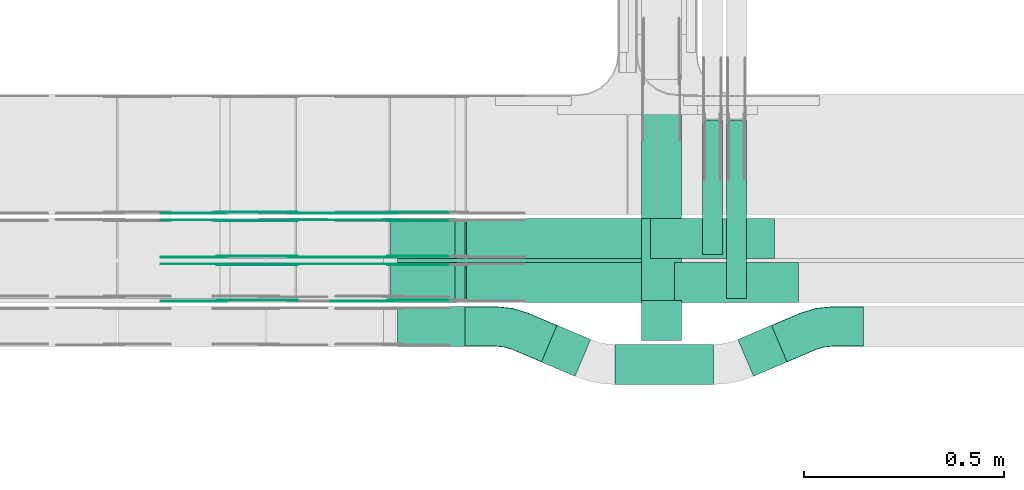
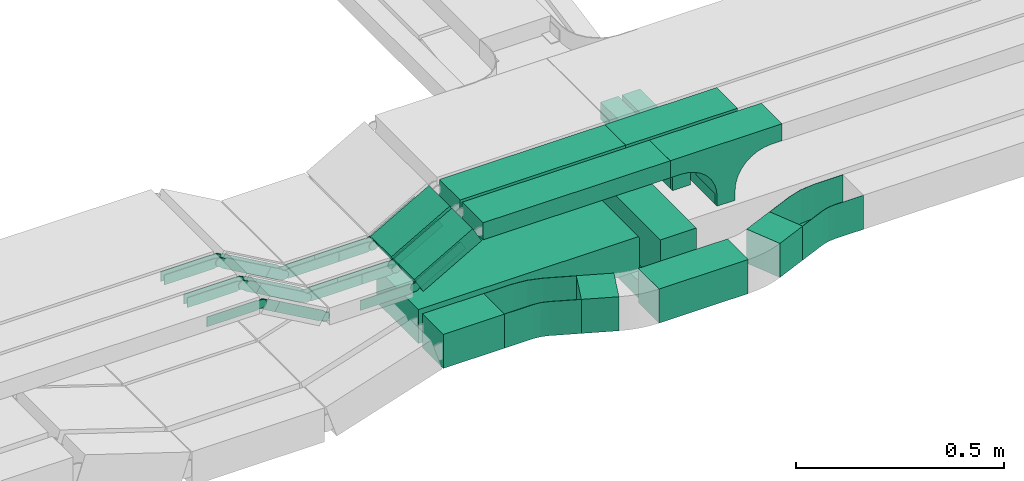
# One storey, part 11 of 27: 34 flow fittings, 13 flow segments.
"""IFC2X3 building model written with IfcOpenShell, lengths in millimetres."""

from ifc_helpers import new_model, entity, si_unit, converted_unit, derived_unit, direction, frame, frame_2d, origin, origin_2d_with_axis, place, context, subcontext, project, spatial, polyline, circle_curve, parameter, trimmed, segment, composite_curve, rectangle, outline, extrude, faceted_brep, source, transform, mapped, material, material_list, type_object, type_shapes, element, save


model = new_model("IFC2X3")

# Units and contexts
model_context = context("Model", 3, precision=0.01, world=origin(), true_north=direction((6.12303176911189e-17, 1.0)))
body_context = subcontext(model_context, "Body", "Model", "MODEL_VIEW")
ifc_project = project(units=[si_unit("LENGTHUNIT", "METRE", prefix="MILLI"), si_unit("AREAUNIT", "SQUARE_METRE"), si_unit("VOLUMEUNIT", "CUBIC_METRE"), converted_unit("PLANEANGLEUNIT", "DEGREE", entity("IfcRatioMeasure", 0.0174532925199433), si_unit("PLANEANGLEUNIT", "RADIAN"), dimensions=[0, 0, 0, 0, 0, 0, 0]), si_unit("MASSUNIT", "GRAM", prefix="KILO"), derived_unit("MASSDENSITYUNIT", [(si_unit("MASSUNIT", "GRAM", prefix="KILO"), 1), (si_unit("LENGTHUNIT", "METRE"), -3)]), derived_unit("MOMENTOFINERTIAUNIT", [(si_unit("LENGTHUNIT", "METRE"), 4)]), si_unit("TIMEUNIT", "SECOND"), si_unit("FREQUENCYUNIT", "HERTZ"), si_unit("THERMODYNAMICTEMPERATUREUNIT", "DEGREE_CELSIUS"), derived_unit("THERMALTRANSMITTANCEUNIT", [(si_unit("MASSUNIT", "GRAM", prefix="KILO"), 1), (si_unit("THERMODYNAMICTEMPERATUREUNIT", "KELVIN"), -1), (si_unit("TIMEUNIT", "SECOND"), -3)]), derived_unit("VOLUMETRICFLOWRATEUNIT", [(si_unit("LENGTHUNIT", "METRE"), 3), (si_unit("TIMEUNIT", "SECOND"), -1)]), derived_unit("MASSFLOWRATEUNIT", [(si_unit("MASSUNIT", "GRAM", prefix="KILO"), 1), (si_unit("TIMEUNIT", "SECOND"), -1)]), derived_unit("ROTATIONALFREQUENCYUNIT", [(si_unit("TIMEUNIT", "SECOND"), -1)]), si_unit("ELECTRICCURRENTUNIT", "AMPERE"), si_unit("ELECTRICVOLTAGEUNIT", "VOLT"), si_unit("POWERUNIT", "WATT"), si_unit("FORCEUNIT", "NEWTON", prefix="KILO"), si_unit("ILLUMINANCEUNIT", "LUX"), si_unit("LUMINOUSFLUXUNIT", "LUMEN"), si_unit("LUMINOUSINTENSITYUNIT", "CANDELA"), derived_unit("USERDEFINED", [(si_unit("MASSUNIT", "GRAM", prefix="KILO"), -1), (si_unit("LENGTHUNIT", "METRE"), -2), (si_unit("TIMEUNIT", "SECOND"), 3), (si_unit("LUMINOUSFLUXUNIT", "LUMEN"), 1)]), derived_unit("LINEARVELOCITYUNIT", [(si_unit("LENGTHUNIT", "METRE"), 1), (si_unit("TIMEUNIT", "SECOND"), -1)]), si_unit("PRESSUREUNIT", "PASCAL"), derived_unit("USERDEFINED", [(si_unit("LENGTHUNIT", "METRE"), -2), (si_unit("MASSUNIT", "GRAM", prefix="KILO"), 1), (si_unit("TIMEUNIT", "SECOND"), -2)]), derived_unit("LINEARFORCEUNIT", [(si_unit("MASSUNIT", "GRAM", prefix="KILO"), 1), (si_unit("LENGTHUNIT", "METRE"), 1), (si_unit("TIMEUNIT", "SECOND"), -2), (si_unit("LENGTHUNIT", "METRE"), -1)]), derived_unit("PLANARFORCEUNIT", [(si_unit("MASSUNIT", "GRAM", prefix="KILO"), 1), (si_unit("LENGTHUNIT", "METRE"), 1), (si_unit("TIMEUNIT", "SECOND"), -2), (si_unit("LENGTHUNIT", "METRE"), -2)])], contexts=[model_context])

# Site, building, storey
site_placement = place(None, origin())
site = spatial("IfcSite", under=ifc_project, at=site_placement, CompositionType="ELEMENT")
building_placement = place(site_placement, origin())
building = spatial("IfcBuilding", under=site, at=building_placement, CompositionType="ELEMENT")
storey_placement = place(building_placement, origin())
storey = spatial("IfcBuildingStorey", under=building, at=storey_placement, CompositionType="ELEMENT", Elevation=0.0)

# Flow segments
cable_carrier_segment_type = type_object("IfcCableCarrierSegmentType", PredefinedType="CABLETRAYSEGMENT")
flow_segment_1_placement = place(storey_placement, frame((35767.46, 8409.92, 2721.0)))
element("IfcFlowSegment", 1, at=flow_segment_1_placement, inside=storey, type_object=cable_carrier_segment_type, context=body_context, shape_type="SweptSolid", body=[
    extrude(rectangle(XDim=446.583630582365, YDim=49.9999999999973, at=origin_2d_with_axis()), frame((25.0, 223.29, 0.0), z_axis=(0.0, 0.0, 1.0), x_axis=(0.0, -1.0, 0.0)), (0.0, 0.0, 1.0), 50.0000000000005),
])
flow_segment_2_placement = place(storey_placement, frame((35488.35, 8195.26, 2600.0)))
element("IfcFlowSegment", 2, at=flow_segment_2_placement, inside=storey, type_object=cable_carrier_segment_type, context=body_context, shape_type="SweptSolid", body=[
    extrude(rectangle(XDim=247.288948924523, YDim=99.9999999999989, at=origin_2d_with_axis()), frame((123.64, 50.0, 0.0)), (0.0, 0.0, 1.0), 100.0),
])
flow_segment_3_placement = place(storey_placement, frame((35304.82, 8215.53, 2600.0)))
element("IfcFlowSegment", 3, at=flow_segment_3_placement, inside=storey, type_object=cable_carrier_segment_type, context=body_context, shape_type="SweptSolid", body=[
    extrude(rectangle(XDim=91.1810821540981, YDim=100.000000000001, at=origin_2d_with_axis()), frame((61.5, 63.84, 0.0), z_axis=(0.0, 0.0, 1.0), x_axis=(0.920504853452403, -0.390731128489362, 0.0)), (0.0, 0.0, 1.0), 100.0),
])
flow_segment_4_placement = place(storey_placement, frame((34944.23, 8290.0, 2600.0)))
element("IfcFlowSegment", 4, at=flow_segment_4_placement, inside=storey, type_object=cable_carrier_segment_type, context=body_context, shape_type="SweptSolid", body=[
    extrude(rectangle(XDim=169.658005217947, YDim=99.9999999999989, at=origin_2d_with_axis()), frame((84.83, 50.0, 0.0), z_axis=(0.0, 0.0, 1.0), x_axis=(-1.0, 0.0, 0.0)), (0.0, 0.0, 1.0), 100.000000000001),
])
flow_segment_5_placement = place(storey_placement, frame((35555.11, 8327.89, 2520.12)))
element("IfcFlowSegment", 5, at=flow_segment_5_placement, inside=storey, type_object=cable_carrier_segment_type, context=body_context, shape_type="SweptSolid", body=[
    extrude(rectangle(XDim=626.717650502026, YDim=100.000000000003, at=origin_2d_with_axis()), frame((50.0, 313.36, 0.0), z_axis=(0.0, 0.0, 1.0), x_axis=(0.0, -1.0, 0.0)), (0.0, 0.0, 1.0), 50.0000000000005),
])
flow_segment_6_placement = place(storey_placement, frame((34944.23, 8410.17, 2600.0)))
element("IfcFlowSegment", 6, at=flow_segment_6_placement, inside=storey, type_object=cable_carrier_segment_type, context=body_context, shape_type="SweptSolid", body=[
    extrude(rectangle(XDim=660.477953416512, YDim=200.0, at=origin_2d_with_axis()), frame((330.24, 100.0, 0.0), z_axis=(0.0, 0.0, 1.0), x_axis=(-1.0, 0.0, 0.0)), (0.0, 0.0, 1.0), 100.0),
])
flow_segment_7_placement = place(storey_placement, frame((35555.11, 8305.17, 2570.12)))
element("IfcFlowSegment", 7, at=flow_segment_7_placement, inside=storey, type_object=cable_carrier_segment_type, context=body_context, shape_type="SweptSolid", body=[
    extrude(rectangle(XDim=100.000000000003, YDim=100.000000000001, at=origin_2d_with_axis()), frame((50.0, 50.0, 0.0), z_axis=(0.0, 0.0, 1.0), x_axis=(-1.0, 0.0, 0.0)), (0.0, 0.0, 1.0), 50.8822343726412),
])
flow_segment_8_placement = place(storey_placement, frame((35796.17, 8215.53, 2600.0)))
element("IfcFlowSegment", 8, at=flow_segment_8_placement, inside=storey, type_object=cable_carrier_segment_type, context=body_context, shape_type="SweptSolid", body=[
    extrude(rectangle(XDim=91.1810821540889, YDim=100.000000000001, at=origin_2d_with_axis()), frame((61.5, 63.84, 0.0), z_axis=(0.0, 0.0, 1.0), x_axis=(-0.920504853452401, -0.390731128489366, 0.0)), (0.0, 0.0, 1.0), 99.9999999999999),
])
flow_segment_9_placement = place(storey_placement, frame((35117.82, 8510.0, 2850.0)))
element("IfcFlowSegment", 9, at=flow_segment_9_placement, inside=storey, type_object=cable_carrier_segment_type, context=body_context, shape_type="SweptSolid", body=[
    extrude(rectangle(XDim=459.62214617131, YDim=100.000000000001, at=origin_2d_with_axis()), frame((229.81, 50.0, 0.0), z_axis=(0.0, 0.0, 1.0), x_axis=(-1.0, 0.0, 0.0)), (0.0, 0.0, 1.0), 50.0000000000011),
])
flow_segment_10_placement = place(storey_placement, frame((35117.82, 8400.0, 2850.0)))
element("IfcFlowSegment", 10, at=flow_segment_10_placement, inside=storey, type_object=cable_carrier_segment_type, context=body_context, shape_type="SweptSolid", body=[
    extrude(rectangle(XDim=519.774157422868, YDim=100.000000000001, at=origin_2d_with_axis()), frame((259.89, 50.0, 0.0), z_axis=(0.0, 0.0, 1.0), x_axis=(-1.0, 0.0, 0.0)), (0.0, 0.0, 1.0), 50.0000000000005),
])
flow_segment_11_placement = place(storey_placement, frame((34927.11, 8400.0, 2756.67)))
element("IfcFlowSegment", 11, at=flow_segment_11_placement, inside=storey, type_object=cable_carrier_segment_type, context=body_context, shape_type="SweptSolid", body=[
    extrude(rectangle(XDim=49.999999999999, YDim=100.000000000001, at=origin_2d_with_axis()), frame((12.37, 50.0, 21.73), z_axis=(0.869016356406197, 0.0, 0.494783358954703), x_axis=(-0.494783358954703, 0.0, 0.869016356406197)), (0.0, 0.0, 1.0), 186.565135152812),
])
flow_segment_12_placement = place(storey_placement, frame((34927.11, 8510.0, 2756.67)))
element("IfcFlowSegment", 12, at=flow_segment_12_placement, inside=storey, type_object=cable_carrier_segment_type, context=body_context, shape_type="SweptSolid", body=[
    extrude(rectangle(XDim=49.9999999999996, YDim=100.000000000001, at=origin_2d_with_axis()), frame((12.37, 50.0, 21.73), z_axis=(0.869016356406348, 0.0, 0.494783358954437), x_axis=(-0.494783358954437, 0.0, 0.869016356406348)), (0.0, 0.0, 1.0), 186.565135152931),
])
flow_segment_13_placement = place(storey_placement, frame((35707.46, 8520.26, 2721.0)))
element("IfcFlowSegment", 13, at=flow_segment_13_placement, inside=storey, type_object=cable_carrier_segment_type, context=body_context, shape_type="SweptSolid", body=[
    extrude(rectangle(XDim=336.244538193396, YDim=49.9999999999973, at=origin_2d_with_axis()), frame((25.0, 168.12, 0.0), z_axis=(0.0, 0.0, 1.0), x_axis=(0.0, -1.0, 0.0)), (0.0, 0.0, 1.0), 50.0000000000005),
])

# Flow fittings
ifc_material_1 = material()
cable_carrier_fitting_type_1 = type_object("IfcCableCarrierFittingType", Name="470_DKC_S5_CPO 45 horizontal angle:-", PredefinedType="NOTDEFINED", material=ifc_material_1)
shared_shape_1 = source(origin(), body_context, "Body", "Brep", [
    faceted_brep([(-109.59, -49.2, -49.2), (-109.59, 49.2, -49.2), (-109.59, 49.2, 50.0), (-109.59, 50.0, 50.0), (-109.59, 50.0, -50.0), (-109.59, -50.0, -50.0), (-109.59, -50.0, 50.0), (-109.59, -49.2, 50.0), (-30.52, -50.0, -50.0), (-30.52, -50.0, 50.0), (9.36, -45.98, 50.0), (47.63, -34.1, 50.0), (120.41, -3.21, 50.0), (120.1, -2.47, 50.0), (47.32, -33.36, 50.0), (9.2, -45.2, 50.0), (-30.52, -49.2, 50.0), (-30.52, 49.2, 50.0), (-10.42, 51.22, 50.0), (8.87, 57.21, 50.0), (81.65, 88.11, 50.0), (81.34, 88.84, 50.0), (8.56, 57.95, 50.0), (-10.58, 52.01, 50.0), (-30.52, 50.0, 50.0), (-30.52, -49.2, -49.2), (9.2, -45.2, -49.2), (47.32, -33.36, -49.2), (120.1, -2.47, -49.2), (81.65, 88.11, -49.2), (8.87, 57.21, -49.2), (-10.42, 51.22, -49.2), (-30.52, 49.2, -49.2), (-30.52, 50.0, -50.0), (-10.58, 52.01, -50.0), (8.56, 57.95, -50.0), (81.34, 88.84, -50.0), (120.41, -3.21, -50.0), (47.63, -34.1, -50.0), (9.36, -45.98, -50.0)], [[[0, 1, 2, 3, 4, 5, 6, 7]], [[6, 5, 8, 9]], [[6, 9, 10, 11, 12, 13, 14, 15, 16, 7]], [[2, 17, 18, 19, 20, 21, 22, 23, 24, 3]], [[0, 7, 16, 25]], [[0, 25, 26, 27, 28, 29, 30, 31, 32, 1]], [[2, 1, 32, 17]], [[4, 3, 24, 33]], [[4, 33, 34, 35, 36, 37, 38, 39, 8, 5]], [[9, 8, 39, 10]], [[39, 38, 11, 10]], [[26, 25, 16, 15]], [[15, 14, 27, 26]], [[17, 32, 31, 18]], [[18, 31, 30, 19]], [[34, 33, 24, 23]], [[22, 35, 34, 23]], [[36, 21, 20, 29, 28, 13, 12, 37]], [[11, 38, 37, 12]], [[27, 14, 13, 28]], [[19, 30, 29, 20]], [[35, 22, 21, 36]]]),
])
type_shapes(cable_carrier_fitting_type_1, [shared_shape_1])
for number, where, z_axis, x_axis, name in (
    (14, (36000.52, 8340.0, 2650.0), (0.0, 0.0, 1.0), (-1.0, 0.0, 0.0), "470_DKC_S5_45 horizontal angle"),
    (15, (35223.48, 8340.0, 2650.0), (0.0, 0.0, 1.0), (-0.920504853452403, 0.390731128489362, 0.0), "470_DKC_S5_45 horizontal angle"),
):
    element("IfcFlowFitting", number, at=place(storey_placement, frame(where, z_axis=z_axis, x_axis=x_axis)), inside=storey, type_object=cable_carrier_fitting_type_1, material=ifc_material_1, Name=name, ObjectType="470_DKC_S5_CPO 45 horizontal angle:-", context=body_context, shape_type="MappedRepresentation", body=[
        mapped(shared_shape_1, transform((0.0, 0.0, 0.0), scale=1.0)),
    ])
ifc_material_2 = material(Name="G")
cable_carrier_fitting_type_2 = type_object("IfcCableCarrierFittingType", PredefinedType="NOTDEFINED", material=ifc_material_2)
shared_shape_2 = source(origin(), body_context, "Body", "SweptSolid", [
    extrude(outline(composite_curve([segment(trimmed(circle_curve(frame_2d((-44.59, 0.0), x_axis=(1.0, 0.0)), 12.5), [parameter(90.0000000000007)], [parameter(270.0)], True, "PARAMETER"), True, "CONTINUOUS"), segment(polyline([(-44.59, -12.5), (-33.09, -12.5)]), True, "CONTINUOUS"), segment(polyline([(-33.09, -12.5), (-31.23, -14.5)]), True, "CONTINUOUS"), segment(polyline([(-31.23, -14.5), (108.91, -14.5)]), True, "CONTINUOUS"), segment(polyline([(108.91, -14.5), (108.91, 14.5)]), True, "CONTINUOUS"), segment(polyline([(108.91, 14.5), (-31.23, 14.5)]), True, "CONTINUOUS"), segment(polyline([(-31.23, 14.5), (-33.09, 12.5)]), True, "CONTINUOUS"), segment(polyline([(-33.09, 12.5), (-44.59, 12.5)]), True, "CONTINUOUS")], self_intersect=False)), frame((44.59, 0.0, 0.0), z_axis=(0.0, 0.0, -1.0), x_axis=(1.0, 0.0, 0.0)), (0.0, 0.0, -1.0), 2.0),
])
type_shapes(cable_carrier_fitting_type_2, [shared_shape_2])
flow_fitting_1_placement = place(storey_placement, frame((34683.26, 8493.46, 2774.1), z_axis=(0.0, 1.0, 0.0), x_axis=(-0.869016356406185, 0.0, 0.494783358954723)))
element("IfcFlowFitting", 16, at=flow_fitting_1_placement, inside=storey, type_object=cable_carrier_fitting_type_2, material=ifc_material_2, context=body_context, shape_type="MappedRepresentation", body=[
    mapped(shared_shape_2, transform((0.0, 0.0, 0.0), scale=1.0)),
])
cable_carrier_fitting_type_3 = type_object("IfcCableCarrierFittingType", PredefinedType="NOTDEFINED", material=ifc_material_2)
type_shapes(cable_carrier_fitting_type_3, [shared_shape_2])
flow_fitting_2_placement = place(storey_placement, frame((34931.93, 8495.46, 2774.1), z_axis=(0.0, 1.0, 0.0), x_axis=(-1.0, 0.0, 0.0)))
element("IfcFlowFitting", 17, at=flow_fitting_2_placement, inside=storey, type_object=cable_carrier_fitting_type_3, material=ifc_material_2, context=body_context, shape_type="MappedRepresentation", body=[
    mapped(shared_shape_2, transform((0.0, 0.0, 0.0), scale=1.0)),
])
flow_fitting_3_placement = place(storey_placement, frame((34931.93, 8406.54, 2774.1), z_axis=(0.0, -1.0, 0.0), x_axis=(0.869016356406185, 0.0, 0.494783358954723)))
element("IfcFlowFitting", 18, at=flow_fitting_3_placement, inside=storey, type_object=cable_carrier_fitting_type_2, material=ifc_material_2, context=body_context, shape_type="MappedRepresentation", body=[
    mapped(shared_shape_2, transform((0.0, 0.0, 0.0), scale=1.0)),
])
flow_fitting_4_placement = place(storey_placement, frame((34683.26, 8514.54, 2774.1), z_axis=(0.0, -1.0, 0.0), x_axis=(1.0, 0.0, 0.0)))
element("IfcFlowFitting", 19, at=flow_fitting_4_placement, inside=storey, type_object=cable_carrier_fitting_type_3, material=ifc_material_2, context=body_context, shape_type="MappedRepresentation", body=[
    mapped(shared_shape_2, transform((0.0, 0.0, 0.0), scale=1.0)),
])
flow_fitting_5_placement = place(storey_placement, frame((34683.26, 8603.46, 2774.1), z_axis=(0.0, 1.0, 0.0), x_axis=(-0.869016356406185, 0.0, 0.494783358954723)))
element("IfcFlowFitting", 20, at=flow_fitting_5_placement, inside=storey, type_object=cable_carrier_fitting_type_2, material=ifc_material_2, context=body_context, shape_type="MappedRepresentation", body=[
    mapped(shared_shape_2, transform((0.0, 0.0, 0.0), scale=1.0)),
])
flow_fitting_6_placement = place(storey_placement, frame((34931.93, 8605.46, 2774.1), z_axis=(0.0, 1.0, 0.0), x_axis=(-1.0, 0.0, 0.0)))
element("IfcFlowFitting", 21, at=flow_fitting_6_placement, inside=storey, type_object=cable_carrier_fitting_type_3, material=ifc_material_2, context=body_context, shape_type="MappedRepresentation", body=[
    mapped(shared_shape_2, transform((0.0, 0.0, 0.0), scale=1.0)),
])
flow_fitting_7_placement = place(storey_placement, frame((34931.93, 8516.54, 2774.1), z_axis=(0.0, -1.0, 0.0), x_axis=(0.869016356406185, 0.0, 0.494783358954723)))
element("IfcFlowFitting", 22, at=flow_fitting_7_placement, inside=storey, type_object=cable_carrier_fitting_type_2, material=ifc_material_2, context=body_context, shape_type="MappedRepresentation", body=[
    mapped(shared_shape_2, transform((0.0, 0.0, 0.0), scale=1.0)),
])
flow_fitting_8_placement = place(storey_placement, frame((34683.26, 8624.54, 2774.1), z_axis=(0.0, -1.0, 0.0), x_axis=(1.0, 0.0, 0.0)))
element("IfcFlowFitting", 23, at=flow_fitting_8_placement, inside=storey, type_object=cable_carrier_fitting_type_3, material=ifc_material_2, context=body_context, shape_type="MappedRepresentation", body=[
    mapped(shared_shape_2, transform((0.0, 0.0, 0.0), scale=1.0)),
])
flow_fitting_9_placement = place(storey_placement, frame((34931.93, 8626.54, 2774.1), z_axis=(0.0, -1.0, 0.0), x_axis=(0.869016356406185, 0.0, 0.494783358954723)))
element("IfcFlowFitting", 24, at=flow_fitting_9_placement, inside=storey, type_object=cable_carrier_fitting_type_2, material=ifc_material_2, context=body_context, shape_type="MappedRepresentation", body=[
    mapped(shared_shape_2, transform((0.0, 0.0, 0.0), scale=1.0)),
])
for number, where, z_axis, x_axis in (
    (25, (34506.05, 8624.54, 2875.0), (0.0, -1.0, 0.0), (-1.0, 0.0, 0.0)),
    (26, (34506.05, 8514.54, 2875.0), (0.0, -1.0, 0.0), (-1.0, 0.0, 0.0)),
):
    element("IfcFlowFitting", number, at=place(storey_placement, frame(where, z_axis=z_axis, x_axis=x_axis)), inside=storey, type_object=cable_carrier_fitting_type_3, material=ifc_material_2, context=body_context, shape_type="MappedRepresentation", body=[
        mapped(shared_shape_2, transform((0.0, 0.0, 0.0), scale=1.0)),
    ])
flow_fitting_10_placement = place(storey_placement, frame((34506.05, 8603.46, 2875.0), z_axis=(0.0, 1.0, 0.0), x_axis=(0.869016356406338, 0.0, -0.494783358954455)))
element("IfcFlowFitting", 27, at=flow_fitting_10_placement, inside=storey, type_object=cable_carrier_fitting_type_2, material=ifc_material_2, context=body_context, shape_type="MappedRepresentation", body=[
    mapped(shared_shape_2, transform((0.0, 0.0, 0.0), scale=1.0)),
])
flow_fitting_11_placement = place(storey_placement, frame((34506.05, 8404.54, 2875.0), z_axis=(0.0, -1.0, 0.0), x_axis=(-1.0, 0.0, 0.0)))
element("IfcFlowFitting", 28, at=flow_fitting_11_placement, inside=storey, type_object=cable_carrier_fitting_type_3, material=ifc_material_2, context=body_context, shape_type="MappedRepresentation", body=[
    mapped(shared_shape_2, transform((0.0, 0.0, 0.0), scale=1.0)),
])
flow_fitting_12_placement = place(storey_placement, frame((34506.05, 8493.46, 2875.0), z_axis=(0.0, 1.0, 0.0), x_axis=(0.869016356406185, 0.0, -0.494783358954723)))
element("IfcFlowFitting", 29, at=flow_fitting_12_placement, inside=storey, type_object=cable_carrier_fitting_type_2, material=ifc_material_2, context=body_context, shape_type="MappedRepresentation", body=[
    mapped(shared_shape_2, transform((0.0, 0.0, 0.0), scale=1.0)),
])
cable_carrier_fitting_type_4 = type_object("IfcCableCarrierFittingType", PredefinedType="NOTDEFINED", material=ifc_material_2)
shared_shape_3 = source(origin(), body_context, "Body", "SweptSolid", [
    extrude(outline(composite_curve([segment(trimmed(circle_curve(frame_2d((-44.59, 0.0), x_axis=(1.0, 0.0)), 12.5), [parameter(90.0000000000007)], [parameter(270.0)], True, "PARAMETER"), True, "CONTINUOUS"), segment(polyline([(-44.59, -12.5), (-33.09, -12.5)]), True, "CONTINUOUS"), segment(polyline([(-33.09, -12.5), (-31.23, -14.5)]), True, "CONTINUOUS"), segment(polyline([(-31.23, -14.5), (108.91, -14.5)]), True, "CONTINUOUS"), segment(polyline([(108.91, -14.5), (108.91, 14.5)]), True, "CONTINUOUS"), segment(polyline([(108.91, 14.5), (-31.23, 14.5)]), True, "CONTINUOUS"), segment(polyline([(-31.23, 14.5), (-33.09, 12.5)]), True, "CONTINUOUS"), segment(polyline([(-33.09, 12.5), (-44.59, 12.5)]), True, "CONTINUOUS")], self_intersect=False)), frame((44.59, 0.0, 0.0)), (0.0, 0.0, 1.0), 2.0),
])
type_shapes(cable_carrier_fitting_type_4, [shared_shape_3])
flow_fitting_13_placement = place(storey_placement, frame((34683.26, 8495.46, 2774.1), z_axis=(0.0, 1.0, 0.0), x_axis=(1.0, 0.0, 0.0)))
element("IfcFlowFitting", 30, at=flow_fitting_13_placement, inside=storey, type_object=cable_carrier_fitting_type_4, material=ifc_material_2, context=body_context, shape_type="MappedRepresentation", body=[
    mapped(shared_shape_3, transform((0.0, 0.0, 0.0), scale=1.0)),
])
cable_carrier_fitting_type_5 = type_object("IfcCableCarrierFittingType", PredefinedType="NOTDEFINED", material=ifc_material_2)
type_shapes(cable_carrier_fitting_type_5, [shared_shape_3])
flow_fitting_14_placement = place(storey_placement, frame((34683.26, 8406.54, 2774.1), z_axis=(0.0, -1.0, 0.0), x_axis=(-0.869016356406185, 0.0, 0.494783358954723)))
element("IfcFlowFitting", 31, at=flow_fitting_14_placement, inside=storey, type_object=cable_carrier_fitting_type_5, material=ifc_material_2, context=body_context, shape_type="MappedRepresentation", body=[
    mapped(shared_shape_3, transform((0.0, 0.0, 0.0), scale=1.0)),
])
flow_fitting_15_placement = place(storey_placement, frame((34931.93, 8404.54, 2774.1), z_axis=(0.0, -1.0, 0.0), x_axis=(-1.0, 0.0, 0.0)))
element("IfcFlowFitting", 32, at=flow_fitting_15_placement, inside=storey, type_object=cable_carrier_fitting_type_4, material=ifc_material_2, context=body_context, shape_type="MappedRepresentation", body=[
    mapped(shared_shape_3, transform((0.0, 0.0, 0.0), scale=1.0)),
])
flow_fitting_16_placement = place(storey_placement, frame((34931.93, 8493.46, 2774.1), z_axis=(0.0, 1.0, 0.0), x_axis=(0.869016356406185, 0.0, 0.494783358954723)))
element("IfcFlowFitting", 33, at=flow_fitting_16_placement, inside=storey, type_object=cable_carrier_fitting_type_5, material=ifc_material_2, context=body_context, shape_type="MappedRepresentation", body=[
    mapped(shared_shape_3, transform((0.0, 0.0, 0.0), scale=1.0)),
])
flow_fitting_17_placement = place(storey_placement, frame((34683.26, 8605.46, 2774.1), z_axis=(0.0, 1.0, 0.0), x_axis=(1.0, 0.0, 0.0)))
element("IfcFlowFitting", 34, at=flow_fitting_17_placement, inside=storey, type_object=cable_carrier_fitting_type_4, material=ifc_material_2, context=body_context, shape_type="MappedRepresentation", body=[
    mapped(shared_shape_3, transform((0.0, 0.0, 0.0), scale=1.0)),
])
flow_fitting_18_placement = place(storey_placement, frame((34683.26, 8516.54, 2774.1), z_axis=(0.0, -1.0, 0.0), x_axis=(-0.869016356406185, 0.0, 0.494783358954723)))
element("IfcFlowFitting", 35, at=flow_fitting_18_placement, inside=storey, type_object=cable_carrier_fitting_type_5, material=ifc_material_2, context=body_context, shape_type="MappedRepresentation", body=[
    mapped(shared_shape_3, transform((0.0, 0.0, 0.0), scale=1.0)),
])
flow_fitting_19_placement = place(storey_placement, frame((34931.93, 8514.54, 2774.1), z_axis=(0.0, -1.0, 0.0), x_axis=(-1.0, 0.0, 0.0)))
element("IfcFlowFitting", 36, at=flow_fitting_19_placement, inside=storey, type_object=cable_carrier_fitting_type_4, material=ifc_material_2, context=body_context, shape_type="MappedRepresentation", body=[
    mapped(shared_shape_3, transform((0.0, 0.0, 0.0), scale=1.0)),
])
for number, where, z_axis, x_axis in (
    (37, (34931.93, 8603.46, 2774.1), (0.0, 1.0, 0.0), (0.869016356406185, 0.0, 0.494783358954723)),
    (38, (34683.26, 8626.54, 2774.1), (0.0, -1.0, 0.0), (-0.869016356406185, 0.0, 0.494783358954723)),
):
    element("IfcFlowFitting", number, at=place(storey_placement, frame(where, z_axis=z_axis, x_axis=x_axis)), inside=storey, type_object=cable_carrier_fitting_type_5, material=ifc_material_2, context=body_context, shape_type="MappedRepresentation", body=[
        mapped(shared_shape_3, transform((0.0, 0.0, 0.0), scale=1.0)),
    ])
flow_fitting_20_placement = place(storey_placement, frame((34931.93, 8624.54, 2774.1), z_axis=(0.0, -1.0, 0.0), x_axis=(-1.0, 0.0, 0.0)))
element("IfcFlowFitting", 39, at=flow_fitting_20_placement, inside=storey, type_object=cable_carrier_fitting_type_4, material=ifc_material_2, context=body_context, shape_type="MappedRepresentation", body=[
    mapped(shared_shape_3, transform((0.0, 0.0, 0.0), scale=1.0)),
])
flow_fitting_21_placement = place(storey_placement, frame((34506.05, 8626.54, 2875.0), z_axis=(0.0, -1.0, 0.0), x_axis=(0.869016356406536, 0.0, -0.494783358954106)))
element("IfcFlowFitting", 40, at=flow_fitting_21_placement, inside=storey, type_object=cable_carrier_fitting_type_5, material=ifc_material_2, context=body_context, shape_type="MappedRepresentation", body=[
    mapped(shared_shape_3, transform((0.0, 0.0, 0.0), scale=1.0)),
])
flow_fitting_22_placement = place(storey_placement, frame((34506.05, 8605.46, 2875.0), z_axis=(0.0, 1.0, 0.0), x_axis=(-1.0, 0.0, 0.0)))
element("IfcFlowFitting", 41, at=flow_fitting_22_placement, inside=storey, type_object=cable_carrier_fitting_type_4, material=ifc_material_2, context=body_context, shape_type="MappedRepresentation", body=[
    mapped(shared_shape_3, transform((0.0, 0.0, 0.0), scale=1.0)),
])
flow_fitting_23_placement = place(storey_placement, frame((34506.05, 8516.54, 2875.0), z_axis=(0.0, -1.0, 0.0), x_axis=(0.869016356406338, 0.0, -0.494783358954455)))
element("IfcFlowFitting", 42, at=flow_fitting_23_placement, inside=storey, type_object=cable_carrier_fitting_type_5, material=ifc_material_2, context=body_context, shape_type="MappedRepresentation", body=[
    mapped(shared_shape_3, transform((0.0, 0.0, 0.0), scale=1.0)),
])
flow_fitting_24_placement = place(storey_placement, frame((34506.05, 8495.46, 2875.0), z_axis=(0.0, 1.0, 0.0), x_axis=(-1.0, 0.0, 0.0)))
element("IfcFlowFitting", 43, at=flow_fitting_24_placement, inside=storey, type_object=cable_carrier_fitting_type_4, material=ifc_material_2, context=body_context, shape_type="MappedRepresentation", body=[
    mapped(shared_shape_3, transform((0.0, 0.0, 0.0), scale=1.0)),
])
flow_fitting_25_placement = place(storey_placement, frame((34506.05, 8406.54, 2875.0), z_axis=(0.0, -1.0, 0.0), x_axis=(0.869016356406185, 0.0, -0.494783358954723)))
element("IfcFlowFitting", 44, at=flow_fitting_25_placement, inside=storey, type_object=cable_carrier_fitting_type_5, material=ifc_material_2, context=body_context, shape_type="MappedRepresentation", body=[
    mapped(shared_shape_3, transform((0.0, 0.0, 0.0), scale=1.0)),
])
ifc_material_list = material_list([ifc_material_1, ifc_material_1, ifc_material_1, ifc_material_1, ifc_material_1])
cable_carrier_fitting_type_6 = type_object("IfcCableCarrierFittingType", PredefinedType="NOTDEFINED", material=ifc_material_list)
shared_shape_4 = source(origin(), body_context, "Body", "SweptSolid", [
    extrude(outline(composite_curve([segment(polyline([(-61.86, -174.29), (-7.86, -174.29)]), True, "CONTINUOUS"), segment(polyline([(-7.86, -174.29), (-7.86, 25.71)]), True, "CONTINUOUS"), segment(trimmed(circle_curve(frame_2d((-2.86, 25.71), x_axis=(0.0, -1.0)), 5.0), [parameter(180.0)], [parameter(270.0)], True, "PARAMETER"), False, "CONTINUOUS"), segment(polyline([(-2.86, 30.71), (71.14, 30.71)]), True, "CONTINUOUS"), segment(polyline([(71.14, 30.71), (71.14, 130.71)]), True, "CONTINUOUS"), segment(polyline([(71.14, 130.71), (-61.86, 130.71)]), True, "CONTINUOUS"), segment(polyline([(-61.86, 130.71), (-61.86, -174.29)]), True, "CONTINUOUS")], self_intersect=False)), frame((-74.29, -50.0, 42.14), z_axis=(0.0, 1.0, 0.0), x_axis=(0.0, 0.0, -1.0)), (0.0, 0.0, 1.0), 0.800000000000055),
    extrude(rectangle(XDim=0.799999999999954, YDim=100.0, at=origin_2d_with_axis()), frame((99.6, 0.0, 17.5), z_axis=(0.0, 0.0, 1.0), x_axis=(-1.0, 0.0, 0.0)), (0.0, 0.0, 1.0), 86.4999999999732),
    extrude(rectangle(XDim=305.0, YDim=100.0, at=origin_2d_with_axis()), frame((-52.5, 0.0, 103.2), z_axis=(0.0, 0.0, 1.0), x_axis=(-1.0, 0.0, 0.0)), (0.0, 0.0, 1.0), 0.800000000000106),
    extrude(rectangle(XDim=0.799999999999852, YDim=98.4000000000001, at=origin_2d_with_axis()), frame((-204.6, 0.0, -29.0), z_axis=(0.0, 0.0, 1.0), x_axis=(-1.0, 0.0, 0.0)), (0.0, 0.0, 1.0), 133.0),
    extrude(outline(composite_curve([segment(polyline([(-61.86, -174.29), (-7.86, -174.29)]), True, "CONTINUOUS"), segment(polyline([(-7.86, -174.29), (-7.86, 25.71)]), True, "CONTINUOUS"), segment(trimmed(circle_curve(frame_2d((-2.86, 25.71), x_axis=(0.0, -1.0)), 5.0), [parameter(180.0)], [parameter(270.0)], True, "PARAMETER"), False, "CONTINUOUS"), segment(polyline([(-2.86, 30.71), (71.14, 30.71)]), True, "CONTINUOUS"), segment(polyline([(71.14, 30.71), (71.14, 130.71)]), True, "CONTINUOUS"), segment(polyline([(71.14, 130.71), (-61.86, 130.71)]), True, "CONTINUOUS"), segment(polyline([(-61.86, 130.71), (-61.86, -174.29)]), True, "CONTINUOUS")], self_intersect=False)), frame((-74.29, 49.2, 42.14), z_axis=(0.0, 1.0, 0.0), x_axis=(0.0, 0.0, -1.0)), (0.0, 0.0, 1.0), 0.799999999999835),
])
type_shapes(cable_carrier_fitting_type_6, [shared_shape_4])
flow_fitting_26_placement = place(storey_placement, frame((35605.11, 8510.17, 2650.0), z_axis=(0.0, 0.0, 1.0), x_axis=(0.0, 1.0, 0.0)))
element("IfcFlowFitting", 45, at=flow_fitting_26_placement, inside=storey, type_object=cable_carrier_fitting_type_6, material=ifc_material_1, Name="470_DKC_S5_vertical T-shaped cover", context=body_context, shape_type="MappedRepresentation", body=[
    mapped(shared_shape_4, transform((0.0, 0.0, 0.0), scale=1.0)),
])
cable_carrier_fitting_type_7 = type_object("IfcCableCarrierFittingType", PredefinedType="NOTDEFINED", material=ifc_material_1)
shared_shape_5 = source(origin(), body_context, "Body", "SweptSolid", [
    extrude(outline(composite_curve([segment(polyline([(-155.0, -85.8), (155.0, -85.8)]), True, "CONTINUOUS"), segment(polyline([(155.0, -85.8), (155.0, -35.8)]), True, "CONTINUOUS"), segment(polyline([(155.0, -35.8), (125.0, -35.8)]), True, "CONTINUOUS"), segment(trimmed(circle_curve(frame_2d((125.0, 64.2), x_axis=(1.0, 0.0)), 99.9999999999926), [parameter(180.0)], [parameter(269.999999999985)], True, "PARAMETER"), False, "CONTINUOUS"), segment(polyline([(25.0, 64.2), (25.0, 93.2)]), True, "CONTINUOUS"), segment(polyline([(25.0, 93.2), (-25.0, 93.2)]), True, "CONTINUOUS"), segment(polyline([(-25.0, 93.2), (-25.0, 64.2)]), True, "CONTINUOUS"), segment(trimmed(circle_curve(frame_2d((-125.0, 64.2), x_axis=(1.0, 0.0)), 99.9999999999768), [parameter(270.0)], [parameter(359.999999999955)], True, "PARAMETER"), False, "CONTINUOUS"), segment(polyline([(-125.0, -35.8), (-155.0, -35.8)]), True, "CONTINUOUS"), segment(polyline([(-155.0, -35.8), (-155.0, -85.8)]), True, "CONTINUOUS")], self_intersect=False)), frame((155.0, -50.0, -60.8), z_axis=(0.0, 1.0, 0.0), x_axis=(1.0, 0.0, 0.0)), (0.0, 0.0, 1.0), 100.0),
])
type_shapes(cable_carrier_fitting_type_7, [shared_shape_5])
for number, where, z_axis, x_axis in (
    (46, (35887.44, 8560.0, 2875.0), (0.0, 0.0, 1.0), (-1.0, 0.0, 0.0)),
    (47, (35947.6, 8450.0, 2875.0), (0.0, 0.0, 1.0), (-1.0, 0.0, 0.0)),
):
    element("IfcFlowFitting", number, at=place(storey_placement, frame(where, z_axis=z_axis, x_axis=x_axis)), inside=storey, type_object=cable_carrier_fitting_type_7, material=ifc_material_1, context=body_context, shape_type="MappedRepresentation", body=[
        mapped(shared_shape_5, transform((0.0, 0.0, 0.0), scale=1.0)),
    ])

save(model, "model.ifc")
